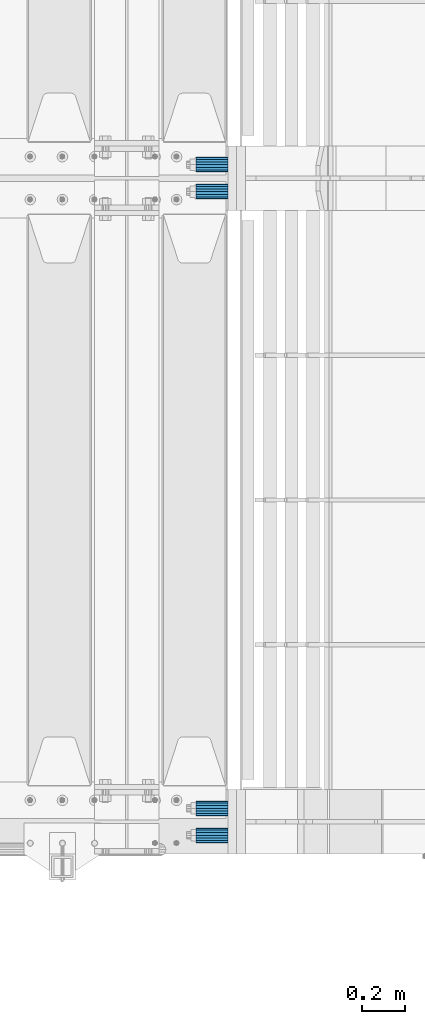
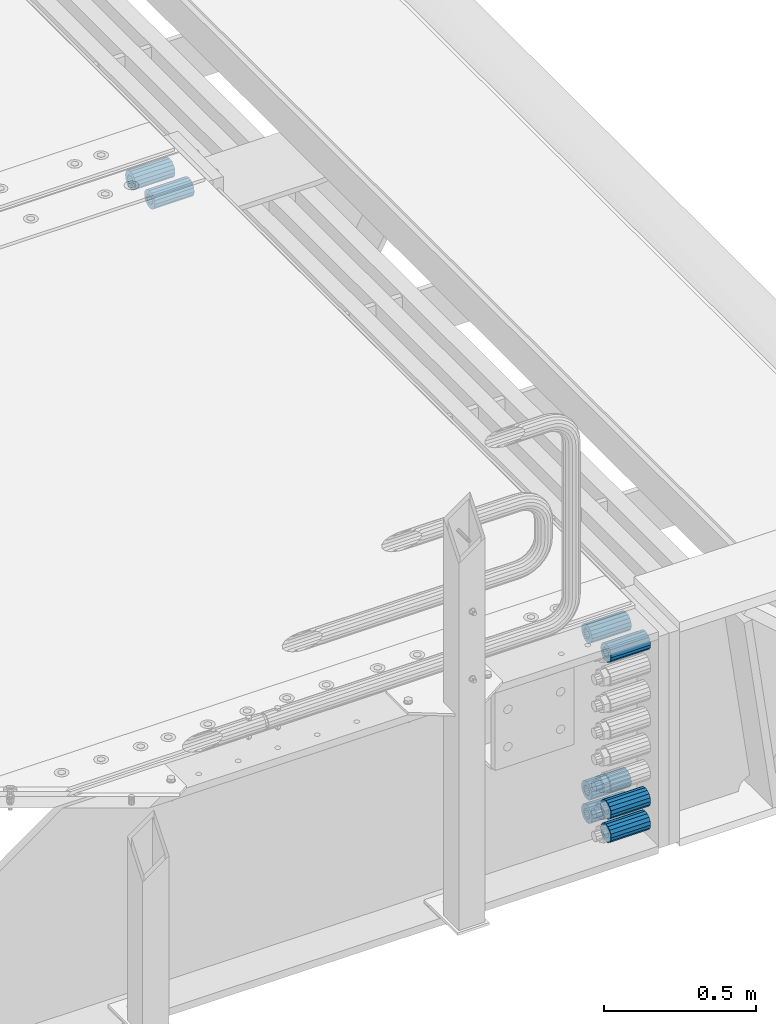
# One storey, part 132 of 208: 8 beams.
"""IFC2X3 building model written with IfcOpenShell, lengths in millimetres."""

from ifc_helpers import new_model, si_unit, frame, origin_with_axes, place, context, subcontext, project, spatial, faceted_brep, material, type_object, element, save


model = new_model("IFC2X3")

# Units and contexts
model_context = context("Model", 3, precision=1e-05, world=origin_with_axes())
body_context = subcontext(model_context, "Body", "Model", "MODEL_VIEW")
ifc_project = project(units=[si_unit("LENGTHUNIT", "METRE", prefix="MILLI"), si_unit("AREAUNIT", "SQUARE_METRE"), si_unit("VOLUMEUNIT", "CUBIC_METRE"), si_unit("MASSUNIT", "GRAM", prefix="KILO"), si_unit("TIMEUNIT", "SECOND"), si_unit("PLANEANGLEUNIT", "RADIAN"), si_unit("SOLIDANGLEUNIT", "STERADIAN"), si_unit("THERMODYNAMICTEMPERATUREUNIT", "DEGREE_CELSIUS"), si_unit("LUMINOUSINTENSITYUNIT", "LUMEN")], contexts=[model_context])

# Site, building, storey
site_placement = place(None, origin_with_axes())
site = spatial("IfcSite", under=ifc_project, at=site_placement, CompositionType="ELEMENT")
building_placement = place(site_placement, origin_with_axes())
building = spatial("IfcBuilding", under=site, at=building_placement, Name="Standard", CompositionType="ELEMENT")
storey_placement = place(building_placement, origin_with_axes())
storey = spatial("IfcBuildingStorey", under=building, at=storey_placement, Name="Undefined", CompositionType="ELEMENT", Elevation=0.0)

# Beams
ifc_material = material()
beam_type = type_object("IfcBeamType", PredefinedType="NOTDEFINED")
beam_1_placement = place(storey_placement, frame((-25783.0, 3063.0, -84.0000000000001), z_axis=(0.0, 0.0, 1.0), x_axis=(1.0, 0.0, 0.0)))
element("IfcBeam", 1, at=beam_1_placement, inside=storey, type_object=beam_type, material=ifc_material, context=body_context, shape_type="Brep", body=[
    faceted_brep([(-1.3120632047503e-07, -18.9999999995496, -6.26459950581193e-09), (0.0, -17.5537111177146, 7.27098521493672), (150.0, -17.5537111177146, 7.27098521493672), (150.0, -19.0, 0.0), (0.0, -13.4350288425444, 13.4350288425444), (150.0, -13.4350288425444, 13.4350288425444), (0.0, -7.2709852149369, 17.5537111177144), (150.0, -7.2709852149369, 17.5537111177144), (-6.33906438451959e-09, 4.50199877377599e-10, 18.9999999937354), (150.0, 0.0, 19.0), (0.0, 7.2709852149369, 17.5537111177144), (150.0, 7.2709852149369, 17.5537111177144), (0.0, 13.4350288425444, 13.4350288425444), (150.0, 13.4350288425444, 13.4350288425444), (0.0, 17.5537111177146, 7.2709852149367), (150.0, 17.5537111177146, 7.2709852149367), (1.33208345687308e-07, 19.0000000004507, -6.26459950581193e-09), (150.0, 19.0, 0.0), (0.0, 17.5537111177146, -7.2709852149367), (150.0, 17.5537111177146, -7.2709852149367), (0.0, 13.4350288425444, -13.4350288425444), (150.0, 13.4350288425444, -13.4350288425444), (0.0, 7.2709852149369, -17.5537111177144), (150.0, 7.2709852149369, -17.5537111177144), (8.34120328363497e-09, 4.50427251053043e-10, -19.0000000062646), (150.0, 0.0, -19.0), (0.0, -7.2709852149369, -17.5537111177144), (150.0, -7.2709852149369, -17.5537111177144), (0.0, -13.4350288425444, -13.4350288425444), (150.0, -13.4350288425444, -13.4350288425444), (0.0, -17.5537111177146, -7.2709852149367), (150.0, -17.5537111177146, -7.2709852149367), (0.0, -35.0, 0.0), (-3.63797880709171e-12, -32.335783637895, -13.3939201327782), (150.0, -32.335783637895, -13.3939201327782), (150.0, -35.0, 0.0), (0.0, -24.7487373415292, -24.7487373415291), (150.0, -24.7487373415293, -24.7487373415292), (0.0, -13.3939201327781, -32.335783637895), (150.0, -13.393920132778, -32.335783637895), (0.0, 0.0, -35.0), (150.0, 0.0, -35.0), (0.0, 13.3939201327782, -32.335783637895), (150.0, 13.393920132778, -32.335783637895), (0.0, 24.7487373415292, -24.7487373415291), (150.0, 24.7487373415293, -24.7487373415292), (-3.63797880709171e-12, 32.335783637895, -13.3939201327782), (150.0, 32.335783637895, -13.3939201327781), (0.0, 35.0, 0.0), (150.0, 35.0, 0.0), (0.0, 32.335783637895, 13.3939201327781), (150.0, 32.335783637895, 13.3939201327781), (0.0, 24.7487373415292, 24.748737341529), (150.0, 24.7487373415293, 24.7487373415292), (0.0, 13.3939201327781, 32.335783637895), (150.0, 13.393920132778, 32.335783637895), (-3.63797880709171e-12, 0.0, 35.0), (150.0, 0.0, 35.0), (0.0, -13.3939201327781, 32.335783637895), (150.0, -13.393920132778, 32.335783637895), (0.0, -24.7487373415292, 24.748737341529), (150.0, -24.7487373415293, 24.7487373415292), (0.0, -32.335783637895, 13.3939201327781), (150.0, -32.335783637895, 13.3939201327781)], [[[0, 1, 2, 3]], [[1, 4, 5, 2]], [[4, 6, 7, 5]], [[6, 8, 9, 7]], [[8, 10, 11, 9]], [[10, 12, 13, 11]], [[12, 14, 15, 13]], [[14, 16, 17, 15]], [[16, 18, 19, 17]], [[18, 20, 21, 19]], [[20, 22, 23, 21]], [[22, 24, 25, 23]], [[24, 26, 27, 25]], [[26, 28, 29, 27]], [[28, 30, 31, 29]], [[30, 0, 3, 31]], [[32, 33, 34, 35]], [[33, 36, 37, 34]], [[36, 38, 39, 37]], [[38, 40, 41, 39]], [[40, 42, 43, 41]], [[42, 44, 45, 43]], [[44, 46, 47, 45]], [[46, 48, 49, 47]], [[48, 50, 51, 49]], [[50, 52, 53, 51]], [[52, 54, 55, 53]], [[54, 56, 57, 55]], [[56, 58, 59, 57]], [[58, 60, 61, 59]], [[60, 62, 63, 61]], [[62, 32, 35, 63]], [[37, 39, 41, 43, 45, 47, 49, 51, 53, 55, 57, 59, 61, 63, 35, 34], [5, 7, 9, 11, 13, 15, 17, 19, 21, 23, 25, 27, 29, 31, 3, 2]], [[62, 60, 58, 56, 54, 52, 50, 48, 46, 44, 42, 40, 38, 36, 33, 32], [30, 28, 26, 24, 22, 20, 18, 16, 14, 12, 10, 8, 6, 4, 1, 0]]]),
])
beam_2_placement = place(storey_placement, frame((-25783.0, 2937.0, -84.0000000000001), z_axis=(0.0, 0.0, 1.0), x_axis=(1.0, 0.0, 0.0)))
element("IfcBeam", 2, at=beam_2_placement, inside=storey, type_object=beam_type, material=ifc_material, context=body_context, shape_type="Brep", body=[
    faceted_brep([(-1.3120632047503e-07, -18.9999999995496, -6.26459950581193e-09), (0.0, -17.5537111177146, 7.27098521493672), (150.0, -17.5537111177146, 7.27098521493672), (150.0, -19.0, 0.0), (0.0, -13.4350288425444, 13.4350288425444), (150.0, -13.4350288425444, 13.4350288425444), (0.0, -7.2709852149369, 17.5537111177144), (150.0, -7.2709852149369, 17.5537111177144), (-6.33906438451959e-09, 4.50199877377599e-10, 18.9999999937354), (150.0, 0.0, 19.0), (0.0, 7.2709852149369, 17.5537111177144), (150.0, 7.2709852149369, 17.5537111177144), (0.0, 13.4350288425444, 13.4350288425444), (150.0, 13.4350288425444, 13.4350288425444), (0.0, 17.5537111177146, 7.2709852149367), (150.0, 17.5537111177146, 7.2709852149367), (1.33208345687308e-07, 19.0000000004507, -6.26459950581193e-09), (150.0, 19.0, 0.0), (0.0, 17.5537111177146, -7.2709852149367), (150.0, 17.5537111177146, -7.2709852149367), (0.0, 13.4350288425444, -13.4350288425444), (150.0, 13.4350288425444, -13.4350288425444), (0.0, 7.2709852149369, -17.5537111177144), (150.0, 7.2709852149369, -17.5537111177144), (8.34120328363497e-09, 4.50427251053043e-10, -19.0000000062646), (150.0, 0.0, -19.0), (0.0, -7.2709852149369, -17.5537111177144), (150.0, -7.2709852149369, -17.5537111177144), (0.0, -13.4350288425444, -13.4350288425444), (150.0, -13.4350288425444, -13.4350288425444), (0.0, -17.5537111177146, -7.2709852149367), (150.0, -17.5537111177146, -7.2709852149367), (0.0, -35.0, 0.0), (-3.63797880709171e-12, -32.335783637895, -13.3939201327782), (150.0, -32.335783637895, -13.3939201327782), (150.0, -35.0, 0.0), (0.0, -24.7487373415292, -24.7487373415291), (150.0, -24.7487373415293, -24.7487373415292), (0.0, -13.3939201327781, -32.335783637895), (150.0, -13.393920132778, -32.335783637895), (0.0, 0.0, -35.0), (150.0, 0.0, -35.0), (0.0, 13.3939201327782, -32.335783637895), (150.0, 13.393920132778, -32.335783637895), (0.0, 24.7487373415292, -24.7487373415291), (150.0, 24.7487373415293, -24.7487373415292), (-3.63797880709171e-12, 32.335783637895, -13.3939201327782), (150.0, 32.335783637895, -13.3939201327781), (0.0, 35.0, 0.0), (150.0, 35.0, 0.0), (0.0, 32.335783637895, 13.3939201327781), (150.0, 32.335783637895, 13.3939201327781), (0.0, 24.7487373415292, 24.748737341529), (150.0, 24.7487373415293, 24.7487373415292), (0.0, 13.3939201327781, 32.335783637895), (150.0, 13.393920132778, 32.335783637895), (-3.63797880709171e-12, 0.0, 35.0), (150.0, 0.0, 35.0), (0.0, -13.3939201327781, 32.335783637895), (150.0, -13.393920132778, 32.335783637895), (0.0, -24.7487373415292, 24.748737341529), (150.0, -24.7487373415293, 24.7487373415292), (0.0, -32.335783637895, 13.3939201327781), (150.0, -32.335783637895, 13.3939201327781)], [[[0, 1, 2, 3]], [[1, 4, 5, 2]], [[4, 6, 7, 5]], [[6, 8, 9, 7]], [[8, 10, 11, 9]], [[10, 12, 13, 11]], [[12, 14, 15, 13]], [[14, 16, 17, 15]], [[16, 18, 19, 17]], [[18, 20, 21, 19]], [[20, 22, 23, 21]], [[22, 24, 25, 23]], [[24, 26, 27, 25]], [[26, 28, 29, 27]], [[28, 30, 31, 29]], [[30, 0, 3, 31]], [[32, 33, 34, 35]], [[33, 36, 37, 34]], [[36, 38, 39, 37]], [[38, 40, 41, 39]], [[40, 42, 43, 41]], [[42, 44, 45, 43]], [[44, 46, 47, 45]], [[46, 48, 49, 47]], [[48, 50, 51, 49]], [[50, 52, 53, 51]], [[52, 54, 55, 53]], [[54, 56, 57, 55]], [[56, 58, 59, 57]], [[58, 60, 61, 59]], [[60, 62, 63, 61]], [[62, 32, 35, 63]], [[37, 39, 41, 43, 45, 47, 49, 51, 53, 55, 57, 59, 61, 63, 35, 34], [5, 7, 9, 11, 13, 15, 17, 19, 21, 23, 25, 27, 29, 31, 3, 2]], [[62, 60, 58, 56, 54, 52, 50, 48, 46, 44, 42, 40, 38, 36, 33, 32], [30, 28, 26, 24, 22, 20, 18, 16, 14, 12, 10, 8, 6, 4, 1, 0]]]),
])
beam_3_placement = place(storey_placement, frame((-25783.0, -63.0, -84.0000000000001), z_axis=(0.0, 0.0, 1.0), x_axis=(1.0, 0.0, 0.0)))
element("IfcBeam", 3, at=beam_3_placement, inside=storey, type_object=beam_type, material=ifc_material, context=body_context, shape_type="Brep", body=[
    faceted_brep([(-1.3120632047503e-07, -18.9999999995496, -6.26459950581193e-09), (0.0, -17.5537111177146, 7.27098521493672), (150.0, -17.5537111177146, 7.27098521493672), (150.0, -19.0, 0.0), (0.0, -13.4350288425444, 13.4350288425444), (150.0, -13.4350288425444, 13.4350288425444), (0.0, -7.2709852149369, 17.5537111177144), (150.0, -7.2709852149369, 17.5537111177144), (-6.33906438451959e-09, 4.50199877377599e-10, 18.9999999937354), (150.0, 0.0, 19.0), (0.0, 7.2709852149369, 17.5537111177144), (150.0, 7.2709852149369, 17.5537111177144), (0.0, 13.4350288425444, 13.4350288425444), (150.0, 13.4350288425444, 13.4350288425444), (0.0, 17.5537111177146, 7.2709852149367), (150.0, 17.5537111177146, 7.2709852149367), (1.33208345687308e-07, 19.0000000004507, -6.26459950581193e-09), (150.0, 19.0, 0.0), (0.0, 17.5537111177146, -7.2709852149367), (150.0, 17.5537111177146, -7.2709852149367), (0.0, 13.4350288425444, -13.4350288425444), (150.0, 13.4350288425444, -13.4350288425444), (0.0, 7.2709852149369, -17.5537111177144), (150.0, 7.2709852149369, -17.5537111177144), (8.34120328363497e-09, 4.50427251053043e-10, -19.0000000062646), (150.0, 0.0, -19.0), (0.0, -7.2709852149369, -17.5537111177144), (150.0, -7.2709852149369, -17.5537111177144), (0.0, -13.4350288425444, -13.4350288425444), (150.0, -13.4350288425444, -13.4350288425444), (0.0, -17.5537111177146, -7.2709852149367), (150.0, -17.5537111177146, -7.2709852149367), (0.0, -35.0, 0.0), (-3.63797880709171e-12, -32.335783637895, -13.3939201327782), (150.0, -32.335783637895, -13.3939201327782), (150.0, -35.0, 0.0), (0.0, -24.7487373415292, -24.7487373415291), (150.0, -24.7487373415293, -24.7487373415292), (0.0, -13.3939201327781, -32.335783637895), (150.0, -13.393920132778, -32.335783637895), (0.0, 0.0, -35.0), (150.0, 0.0, -35.0), (0.0, 13.3939201327782, -32.335783637895), (150.0, 13.393920132778, -32.335783637895), (0.0, 24.7487373415292, -24.7487373415291), (150.0, 24.7487373415293, -24.7487373415292), (-3.63797880709171e-12, 32.335783637895, -13.3939201327782), (150.0, 32.335783637895, -13.3939201327781), (0.0, 35.0, 0.0), (150.0, 35.0, 0.0), (0.0, 32.335783637895, 13.3939201327781), (150.0, 32.335783637895, 13.3939201327781), (0.0, 24.7487373415292, 24.748737341529), (150.0, 24.7487373415293, 24.7487373415292), (0.0, 13.3939201327781, 32.335783637895), (150.0, 13.393920132778, 32.335783637895), (-3.63797880709171e-12, 0.0, 35.0), (150.0, 0.0, 35.0), (0.0, -13.3939201327781, 32.335783637895), (150.0, -13.393920132778, 32.335783637895), (0.0, -24.7487373415292, 24.748737341529), (150.0, -24.7487373415293, 24.7487373415292), (0.0, -32.335783637895, 13.3939201327781), (150.0, -32.335783637895, 13.3939201327781)], [[[0, 1, 2, 3]], [[1, 4, 5, 2]], [[4, 6, 7, 5]], [[6, 8, 9, 7]], [[8, 10, 11, 9]], [[10, 12, 13, 11]], [[12, 14, 15, 13]], [[14, 16, 17, 15]], [[16, 18, 19, 17]], [[18, 20, 21, 19]], [[20, 22, 23, 21]], [[22, 24, 25, 23]], [[24, 26, 27, 25]], [[26, 28, 29, 27]], [[28, 30, 31, 29]], [[30, 0, 3, 31]], [[32, 33, 34, 35]], [[33, 36, 37, 34]], [[36, 38, 39, 37]], [[38, 40, 41, 39]], [[40, 42, 43, 41]], [[42, 44, 45, 43]], [[44, 46, 47, 45]], [[46, 48, 49, 47]], [[48, 50, 51, 49]], [[50, 52, 53, 51]], [[52, 54, 55, 53]], [[54, 56, 57, 55]], [[56, 58, 59, 57]], [[58, 60, 61, 59]], [[60, 62, 63, 61]], [[62, 32, 35, 63]], [[37, 39, 41, 43, 45, 47, 49, 51, 53, 55, 57, 59, 61, 63, 35, 34], [5, 7, 9, 11, 13, 15, 17, 19, 21, 23, 25, 27, 29, 31, 3, 2]], [[62, 60, 58, 56, 54, 52, 50, 48, 46, 44, 42, 40, 38, 36, 33, 32], [30, 28, 26, 24, 22, 20, 18, 16, 14, 12, 10, 8, 6, 4, 1, 0]]]),
])
beam_4_placement = place(storey_placement, frame((-25783.0, 63.0, -713.0), z_axis=(0.0, 0.0, 1.0), x_axis=(1.0, 0.0, 0.0)))
element("IfcBeam", 4, at=beam_4_placement, inside=storey, type_object=beam_type, material=ifc_material, context=body_context, shape_type="Brep", body=[
    faceted_brep([(-1.3120632047503e-07, -18.9999999995496, -6.26459950581193e-09), (0.0, -17.5537111177146, 7.27098521493672), (150.0, -17.5537111177146, 7.27098521493672), (150.0, -19.0, 0.0), (0.0, -13.4350288425444, 13.4350288425444), (150.0, -13.4350288425444, 13.4350288425444), (0.0, -7.2709852149369, 17.5537111177144), (150.0, -7.2709852149369, 17.5537111177144), (-6.33906438451959e-09, 4.50199877377599e-10, 18.9999999937354), (150.0, 0.0, 19.0), (0.0, 7.2709852149369, 17.5537111177144), (150.0, 7.2709852149369, 17.5537111177144), (0.0, 13.4350288425444, 13.4350288425444), (150.0, 13.4350288425444, 13.4350288425444), (0.0, 17.5537111177146, 7.2709852149367), (150.0, 17.5537111177146, 7.2709852149367), (1.33208345687308e-07, 19.0000000004507, -6.26459950581193e-09), (150.0, 19.0, 0.0), (0.0, 17.5537111177146, -7.2709852149367), (150.0, 17.5537111177146, -7.2709852149367), (0.0, 13.4350288425444, -13.4350288425444), (150.0, 13.4350288425444, -13.4350288425444), (0.0, 7.2709852149369, -17.5537111177144), (150.0, 7.2709852149369, -17.5537111177144), (8.34120328363497e-09, 4.50427251053043e-10, -19.0000000062646), (150.0, 0.0, -19.0), (0.0, -7.2709852149369, -17.5537111177144), (150.0, -7.2709852149369, -17.5537111177144), (0.0, -13.4350288425444, -13.4350288425444), (150.0, -13.4350288425444, -13.4350288425444), (0.0, -17.5537111177146, -7.2709852149367), (150.0, -17.5537111177146, -7.2709852149367), (0.0, -35.0, 0.0), (-3.63797880709171e-12, -32.335783637895, -13.3939201327782), (150.0, -32.335783637895, -13.3939201327782), (150.0, -35.0, 0.0), (0.0, -24.7487373415292, -24.7487373415291), (150.0, -24.7487373415293, -24.7487373415292), (0.0, -13.3939201327781, -32.335783637895), (150.0, -13.393920132778, -32.335783637895), (0.0, 0.0, -35.0), (150.0, 0.0, -35.0), (0.0, 13.3939201327782, -32.335783637895), (150.0, 13.393920132778, -32.335783637895), (0.0, 24.7487373415292, -24.7487373415291), (150.0, 24.7487373415293, -24.7487373415292), (-3.63797880709171e-12, 32.335783637895, -13.3939201327782), (150.0, 32.335783637895, -13.3939201327781), (0.0, 35.0, 0.0), (150.0, 35.0, 0.0), (0.0, 32.335783637895, 13.3939201327781), (150.0, 32.335783637895, 13.3939201327781), (0.0, 24.7487373415292, 24.748737341529), (150.0, 24.7487373415293, 24.7487373415292), (0.0, 13.3939201327781, 32.335783637895), (150.0, 13.393920132778, 32.335783637895), (-3.63797880709171e-12, 0.0, 35.0), (150.0, 0.0, 35.0), (0.0, -13.3939201327781, 32.335783637895), (150.0, -13.393920132778, 32.335783637895), (0.0, -24.7487373415292, 24.748737341529), (150.0, -24.7487373415293, 24.7487373415292), (0.0, -32.335783637895, 13.3939201327781), (150.0, -32.335783637895, 13.3939201327781)], [[[0, 1, 2, 3]], [[1, 4, 5, 2]], [[4, 6, 7, 5]], [[6, 8, 9, 7]], [[8, 10, 11, 9]], [[10, 12, 13, 11]], [[12, 14, 15, 13]], [[14, 16, 17, 15]], [[16, 18, 19, 17]], [[18, 20, 21, 19]], [[20, 22, 23, 21]], [[22, 24, 25, 23]], [[24, 26, 27, 25]], [[26, 28, 29, 27]], [[28, 30, 31, 29]], [[30, 0, 3, 31]], [[32, 33, 34, 35]], [[33, 36, 37, 34]], [[36, 38, 39, 37]], [[38, 40, 41, 39]], [[40, 42, 43, 41]], [[42, 44, 45, 43]], [[44, 46, 47, 45]], [[46, 48, 49, 47]], [[48, 50, 51, 49]], [[50, 52, 53, 51]], [[52, 54, 55, 53]], [[54, 56, 57, 55]], [[56, 58, 59, 57]], [[58, 60, 61, 59]], [[60, 62, 63, 61]], [[62, 32, 35, 63]], [[37, 39, 41, 43, 45, 47, 49, 51, 53, 55, 57, 59, 61, 63, 35, 34], [5, 7, 9, 11, 13, 15, 17, 19, 21, 23, 25, 27, 29, 31, 3, 2]], [[62, 60, 58, 56, 54, 52, 50, 48, 46, 44, 42, 40, 38, 36, 33, 32], [30, 28, 26, 24, 22, 20, 18, 16, 14, 12, 10, 8, 6, 4, 1, 0]]]),
])
beam_5_placement = place(storey_placement, frame((-25783.0, 63.0, -84.0000000000001), z_axis=(0.0, 0.0, 1.0), x_axis=(1.0, 0.0, 0.0)))
element("IfcBeam", 5, at=beam_5_placement, inside=storey, type_object=beam_type, material=ifc_material, context=body_context, shape_type="Brep", body=[
    faceted_brep([(-1.3120632047503e-07, -18.9999999995496, -6.26459950581193e-09), (0.0, -17.5537111177146, 7.27098521493672), (150.0, -17.5537111177146, 7.27098521493672), (150.0, -19.0, 0.0), (0.0, -13.4350288425444, 13.4350288425444), (150.0, -13.4350288425444, 13.4350288425444), (0.0, -7.2709852149369, 17.5537111177144), (150.0, -7.2709852149369, 17.5537111177144), (-6.33906438451959e-09, 4.50199877377599e-10, 18.9999999937354), (150.0, 0.0, 19.0), (0.0, 7.2709852149369, 17.5537111177144), (150.0, 7.2709852149369, 17.5537111177144), (0.0, 13.4350288425444, 13.4350288425444), (150.0, 13.4350288425444, 13.4350288425444), (0.0, 17.5537111177146, 7.2709852149367), (150.0, 17.5537111177146, 7.2709852149367), (1.33208345687308e-07, 19.0000000004507, -6.26459950581193e-09), (150.0, 19.0, 0.0), (0.0, 17.5537111177146, -7.2709852149367), (150.0, 17.5537111177146, -7.2709852149367), (0.0, 13.4350288425444, -13.4350288425444), (150.0, 13.4350288425444, -13.4350288425444), (0.0, 7.2709852149369, -17.5537111177144), (150.0, 7.2709852149369, -17.5537111177144), (8.34120328363497e-09, 4.50427251053043e-10, -19.0000000062646), (150.0, 0.0, -19.0), (0.0, -7.2709852149369, -17.5537111177144), (150.0, -7.2709852149369, -17.5537111177144), (0.0, -13.4350288425444, -13.4350288425444), (150.0, -13.4350288425444, -13.4350288425444), (0.0, -17.5537111177146, -7.2709852149367), (150.0, -17.5537111177146, -7.2709852149367), (0.0, -35.0, 0.0), (-3.63797880709171e-12, -32.335783637895, -13.3939201327782), (150.0, -32.335783637895, -13.3939201327782), (150.0, -35.0, 0.0), (0.0, -24.7487373415292, -24.7487373415291), (150.0, -24.7487373415293, -24.7487373415292), (0.0, -13.3939201327781, -32.335783637895), (150.0, -13.393920132778, -32.335783637895), (0.0, 0.0, -35.0), (150.0, 0.0, -35.0), (0.0, 13.3939201327782, -32.335783637895), (150.0, 13.393920132778, -32.335783637895), (0.0, 24.7487373415292, -24.7487373415291), (150.0, 24.7487373415293, -24.7487373415292), (-3.63797880709171e-12, 32.335783637895, -13.3939201327782), (150.0, 32.335783637895, -13.3939201327781), (0.0, 35.0, 0.0), (150.0, 35.0, 0.0), (0.0, 32.335783637895, 13.3939201327781), (150.0, 32.335783637895, 13.3939201327781), (0.0, 24.7487373415292, 24.748737341529), (150.0, 24.7487373415293, 24.7487373415292), (0.0, 13.3939201327781, 32.335783637895), (150.0, 13.393920132778, 32.335783637895), (-3.63797880709171e-12, 0.0, 35.0), (150.0, 0.0, 35.0), (0.0, -13.3939201327781, 32.335783637895), (150.0, -13.393920132778, 32.335783637895), (0.0, -24.7487373415292, 24.748737341529), (150.0, -24.7487373415293, 24.7487373415292), (0.0, -32.335783637895, 13.3939201327781), (150.0, -32.335783637895, 13.3939201327781)], [[[0, 1, 2, 3]], [[1, 4, 5, 2]], [[4, 6, 7, 5]], [[6, 8, 9, 7]], [[8, 10, 11, 9]], [[10, 12, 13, 11]], [[12, 14, 15, 13]], [[14, 16, 17, 15]], [[16, 18, 19, 17]], [[18, 20, 21, 19]], [[20, 22, 23, 21]], [[22, 24, 25, 23]], [[24, 26, 27, 25]], [[26, 28, 29, 27]], [[28, 30, 31, 29]], [[30, 0, 3, 31]], [[32, 33, 34, 35]], [[33, 36, 37, 34]], [[36, 38, 39, 37]], [[38, 40, 41, 39]], [[40, 42, 43, 41]], [[42, 44, 45, 43]], [[44, 46, 47, 45]], [[46, 48, 49, 47]], [[48, 50, 51, 49]], [[50, 52, 53, 51]], [[52, 54, 55, 53]], [[54, 56, 57, 55]], [[56, 58, 59, 57]], [[58, 60, 61, 59]], [[60, 62, 63, 61]], [[62, 32, 35, 63]], [[37, 39, 41, 43, 45, 47, 49, 51, 53, 55, 57, 59, 61, 63, 35, 34], [5, 7, 9, 11, 13, 15, 17, 19, 21, 23, 25, 27, 29, 31, 3, 2]], [[62, 60, 58, 56, 54, 52, 50, 48, 46, 44, 42, 40, 38, 36, 33, 32], [30, 28, 26, 24, 22, 20, 18, 16, 14, 12, 10, 8, 6, 4, 1, 0]]]),
])
beam_6_placement = place(storey_placement, frame((-25783.0, -63.0, -713.0), z_axis=(0.0, 0.0, 1.0), x_axis=(1.0, 0.0, 0.0)))
element("IfcBeam", 6, at=beam_6_placement, inside=storey, type_object=beam_type, material=ifc_material, context=body_context, shape_type="Brep", body=[
    faceted_brep([(-1.3120632047503e-07, -18.9999999995496, -6.26459950581193e-09), (0.0, -17.5537111177146, 7.27098521493672), (150.0, -17.5537111177146, 7.27098521493672), (150.0, -19.0, 0.0), (0.0, -13.4350288425444, 13.4350288425444), (150.0, -13.4350288425444, 13.4350288425444), (0.0, -7.2709852149369, 17.5537111177144), (150.0, -7.2709852149369, 17.5537111177144), (-6.33906438451959e-09, 4.50199877377599e-10, 18.9999999937354), (150.0, 0.0, 19.0), (0.0, 7.2709852149369, 17.5537111177144), (150.0, 7.2709852149369, 17.5537111177144), (0.0, 13.4350288425444, 13.4350288425444), (150.0, 13.4350288425444, 13.4350288425444), (0.0, 17.5537111177146, 7.2709852149367), (150.0, 17.5537111177146, 7.2709852149367), (1.33208345687308e-07, 19.0000000004507, -6.26459950581193e-09), (150.0, 19.0, 0.0), (0.0, 17.5537111177146, -7.2709852149367), (150.0, 17.5537111177146, -7.2709852149367), (0.0, 13.4350288425444, -13.4350288425444), (150.0, 13.4350288425444, -13.4350288425444), (0.0, 7.2709852149369, -17.5537111177144), (150.0, 7.2709852149369, -17.5537111177144), (8.34120328363497e-09, 4.50427251053043e-10, -19.0000000062646), (150.0, 0.0, -19.0), (0.0, -7.2709852149369, -17.5537111177144), (150.0, -7.2709852149369, -17.5537111177144), (0.0, -13.4350288425444, -13.4350288425444), (150.0, -13.4350288425444, -13.4350288425444), (0.0, -17.5537111177146, -7.2709852149367), (150.0, -17.5537111177146, -7.2709852149367), (0.0, -35.0, 0.0), (-3.63797880709171e-12, -32.335783637895, -13.3939201327782), (150.0, -32.335783637895, -13.3939201327782), (150.0, -35.0, 0.0), (0.0, -24.7487373415292, -24.7487373415291), (150.0, -24.7487373415293, -24.7487373415292), (0.0, -13.3939201327781, -32.335783637895), (150.0, -13.393920132778, -32.335783637895), (0.0, 0.0, -35.0), (150.0, 0.0, -35.0), (0.0, 13.3939201327782, -32.335783637895), (150.0, 13.393920132778, -32.335783637895), (0.0, 24.7487373415292, -24.7487373415291), (150.0, 24.7487373415293, -24.7487373415292), (-3.63797880709171e-12, 32.335783637895, -13.3939201327782), (150.0, 32.335783637895, -13.3939201327781), (0.0, 35.0, 0.0), (150.0, 35.0, 0.0), (0.0, 32.335783637895, 13.3939201327781), (150.0, 32.335783637895, 13.3939201327781), (0.0, 24.7487373415292, 24.748737341529), (150.0, 24.7487373415293, 24.7487373415292), (0.0, 13.3939201327781, 32.335783637895), (150.0, 13.393920132778, 32.335783637895), (-3.63797880709171e-12, 0.0, 35.0), (150.0, 0.0, 35.0), (0.0, -13.3939201327781, 32.335783637895), (150.0, -13.393920132778, 32.335783637895), (0.0, -24.7487373415292, 24.748737341529), (150.0, -24.7487373415293, 24.7487373415292), (0.0, -32.335783637895, 13.3939201327781), (150.0, -32.335783637895, 13.3939201327781)], [[[0, 1, 2, 3]], [[1, 4, 5, 2]], [[4, 6, 7, 5]], [[6, 8, 9, 7]], [[8, 10, 11, 9]], [[10, 12, 13, 11]], [[12, 14, 15, 13]], [[14, 16, 17, 15]], [[16, 18, 19, 17]], [[18, 20, 21, 19]], [[20, 22, 23, 21]], [[22, 24, 25, 23]], [[24, 26, 27, 25]], [[26, 28, 29, 27]], [[28, 30, 31, 29]], [[30, 0, 3, 31]], [[32, 33, 34, 35]], [[33, 36, 37, 34]], [[36, 38, 39, 37]], [[38, 40, 41, 39]], [[40, 42, 43, 41]], [[42, 44, 45, 43]], [[44, 46, 47, 45]], [[46, 48, 49, 47]], [[48, 50, 51, 49]], [[50, 52, 53, 51]], [[52, 54, 55, 53]], [[54, 56, 57, 55]], [[56, 58, 59, 57]], [[58, 60, 61, 59]], [[60, 62, 63, 61]], [[62, 32, 35, 63]], [[37, 39, 41, 43, 45, 47, 49, 51, 53, 55, 57, 59, 61, 63, 35, 34], [5, 7, 9, 11, 13, 15, 17, 19, 21, 23, 25, 27, 29, 31, 3, 2]], [[62, 60, 58, 56, 54, 52, 50, 48, 46, 44, 42, 40, 38, 36, 33, 32], [30, 28, 26, 24, 22, 20, 18, 16, 14, 12, 10, 8, 6, 4, 1, 0]]]),
])
beam_7_placement = place(storey_placement, frame((-25783.0, 63.0, -807.0), z_axis=(0.0, 0.0, 1.0), x_axis=(1.0, 0.0, 0.0)))
element("IfcBeam", 7, at=beam_7_placement, inside=storey, type_object=beam_type, material=ifc_material, context=body_context, shape_type="Brep", body=[
    faceted_brep([(-1.3120632047503e-07, -18.9999999995496, -6.26459950581193e-09), (0.0, -17.5537111177146, 7.27098521493672), (150.0, -17.5537111177146, 7.27098521493672), (150.0, -19.0, 0.0), (0.0, -13.4350288425444, 13.4350288425444), (150.0, -13.4350288425444, 13.4350288425444), (0.0, -7.2709852149369, 17.5537111177144), (150.0, -7.2709852149369, 17.5537111177144), (-6.33906438451959e-09, 4.50199877377599e-10, 18.9999999937354), (150.0, 0.0, 19.0), (0.0, 7.2709852149369, 17.5537111177144), (150.0, 7.2709852149369, 17.5537111177144), (0.0, 13.4350288425444, 13.4350288425444), (150.0, 13.4350288425444, 13.4350288425444), (0.0, 17.5537111177146, 7.2709852149367), (150.0, 17.5537111177146, 7.2709852149367), (1.33208345687308e-07, 19.0000000004507, -6.26459950581193e-09), (150.0, 19.0, 0.0), (0.0, 17.5537111177146, -7.2709852149367), (150.0, 17.5537111177146, -7.2709852149367), (0.0, 13.4350288425444, -13.4350288425444), (150.0, 13.4350288425444, -13.4350288425444), (0.0, 7.2709852149369, -17.5537111177144), (150.0, 7.2709852149369, -17.5537111177144), (8.34120328363497e-09, 4.50427251053043e-10, -19.0000000062646), (150.0, 0.0, -19.0), (0.0, -7.2709852149369, -17.5537111177144), (150.0, -7.2709852149369, -17.5537111177144), (0.0, -13.4350288425444, -13.4350288425444), (150.0, -13.4350288425444, -13.4350288425444), (0.0, -17.5537111177146, -7.2709852149367), (150.0, -17.5537111177146, -7.2709852149367), (0.0, -35.0, 0.0), (-3.63797880709171e-12, -32.335783637895, -13.3939201327782), (150.0, -32.335783637895, -13.3939201327782), (150.0, -35.0, 0.0), (0.0, -24.7487373415292, -24.7487373415291), (150.0, -24.7487373415293, -24.7487373415292), (0.0, -13.3939201327781, -32.335783637895), (150.0, -13.393920132778, -32.335783637895), (0.0, 0.0, -35.0), (150.0, 0.0, -35.0), (0.0, 13.3939201327782, -32.335783637895), (150.0, 13.393920132778, -32.335783637895), (0.0, 24.7487373415292, -24.7487373415291), (150.0, 24.7487373415293, -24.7487373415292), (-3.63797880709171e-12, 32.335783637895, -13.3939201327782), (150.0, 32.335783637895, -13.3939201327781), (0.0, 35.0, 0.0), (150.0, 35.0, 0.0), (0.0, 32.335783637895, 13.3939201327781), (150.0, 32.335783637895, 13.3939201327781), (0.0, 24.7487373415292, 24.748737341529), (150.0, 24.7487373415293, 24.7487373415292), (0.0, 13.3939201327781, 32.335783637895), (150.0, 13.393920132778, 32.335783637895), (-3.63797880709171e-12, 0.0, 35.0), (150.0, 0.0, 35.0), (0.0, -13.3939201327781, 32.335783637895), (150.0, -13.393920132778, 32.335783637895), (0.0, -24.7487373415292, 24.748737341529), (150.0, -24.7487373415293, 24.7487373415292), (0.0, -32.335783637895, 13.3939201327781), (150.0, -32.335783637895, 13.3939201327781)], [[[0, 1, 2, 3]], [[1, 4, 5, 2]], [[4, 6, 7, 5]], [[6, 8, 9, 7]], [[8, 10, 11, 9]], [[10, 12, 13, 11]], [[12, 14, 15, 13]], [[14, 16, 17, 15]], [[16, 18, 19, 17]], [[18, 20, 21, 19]], [[20, 22, 23, 21]], [[22, 24, 25, 23]], [[24, 26, 27, 25]], [[26, 28, 29, 27]], [[28, 30, 31, 29]], [[30, 0, 3, 31]], [[32, 33, 34, 35]], [[33, 36, 37, 34]], [[36, 38, 39, 37]], [[38, 40, 41, 39]], [[40, 42, 43, 41]], [[42, 44, 45, 43]], [[44, 46, 47, 45]], [[46, 48, 49, 47]], [[48, 50, 51, 49]], [[50, 52, 53, 51]], [[52, 54, 55, 53]], [[54, 56, 57, 55]], [[56, 58, 59, 57]], [[58, 60, 61, 59]], [[60, 62, 63, 61]], [[62, 32, 35, 63]], [[37, 39, 41, 43, 45, 47, 49, 51, 53, 55, 57, 59, 61, 63, 35, 34], [5, 7, 9, 11, 13, 15, 17, 19, 21, 23, 25, 27, 29, 31, 3, 2]], [[62, 60, 58, 56, 54, 52, 50, 48, 46, 44, 42, 40, 38, 36, 33, 32], [30, 28, 26, 24, 22, 20, 18, 16, 14, 12, 10, 8, 6, 4, 1, 0]]]),
])
beam_8_placement = place(storey_placement, frame((-25783.0, -63.0, -807.0), z_axis=(0.0, 0.0, 1.0), x_axis=(1.0, 0.0, 0.0)))
element("IfcBeam", 8, at=beam_8_placement, inside=storey, type_object=beam_type, material=ifc_material, context=body_context, shape_type="Brep", body=[
    faceted_brep([(-1.3120632047503e-07, -18.9999999995496, -6.26459950581193e-09), (0.0, -17.5537111177146, 7.27098521493672), (150.0, -17.5537111177146, 7.27098521493672), (150.0, -19.0, 0.0), (0.0, -13.4350288425444, 13.4350288425444), (150.0, -13.4350288425444, 13.4350288425444), (0.0, -7.2709852149369, 17.5537111177144), (150.0, -7.2709852149369, 17.5537111177144), (-6.33906438451959e-09, 4.50199877377599e-10, 18.9999999937354), (150.0, 0.0, 19.0), (0.0, 7.2709852149369, 17.5537111177144), (150.0, 7.2709852149369, 17.5537111177144), (0.0, 13.4350288425444, 13.4350288425444), (150.0, 13.4350288425444, 13.4350288425444), (0.0, 17.5537111177146, 7.2709852149367), (150.0, 17.5537111177146, 7.2709852149367), (1.33208345687308e-07, 19.0000000004507, -6.26459950581193e-09), (150.0, 19.0, 0.0), (0.0, 17.5537111177146, -7.2709852149367), (150.0, 17.5537111177146, -7.2709852149367), (0.0, 13.4350288425444, -13.4350288425444), (150.0, 13.4350288425444, -13.4350288425444), (0.0, 7.2709852149369, -17.5537111177144), (150.0, 7.2709852149369, -17.5537111177144), (8.34120328363497e-09, 4.50427251053043e-10, -19.0000000062646), (150.0, 0.0, -19.0), (0.0, -7.2709852149369, -17.5537111177144), (150.0, -7.2709852149369, -17.5537111177144), (0.0, -13.4350288425444, -13.4350288425444), (150.0, -13.4350288425444, -13.4350288425444), (0.0, -17.5537111177146, -7.2709852149367), (150.0, -17.5537111177146, -7.2709852149367), (0.0, -35.0, 0.0), (-3.63797880709171e-12, -32.335783637895, -13.3939201327782), (150.0, -32.335783637895, -13.3939201327782), (150.0, -35.0, 0.0), (0.0, -24.7487373415292, -24.7487373415291), (150.0, -24.7487373415293, -24.7487373415292), (0.0, -13.3939201327781, -32.335783637895), (150.0, -13.393920132778, -32.335783637895), (0.0, 0.0, -35.0), (150.0, 0.0, -35.0), (0.0, 13.3939201327782, -32.335783637895), (150.0, 13.393920132778, -32.335783637895), (0.0, 24.7487373415292, -24.7487373415291), (150.0, 24.7487373415293, -24.7487373415292), (-3.63797880709171e-12, 32.335783637895, -13.3939201327782), (150.0, 32.335783637895, -13.3939201327781), (0.0, 35.0, 0.0), (150.0, 35.0, 0.0), (0.0, 32.335783637895, 13.3939201327781), (150.0, 32.335783637895, 13.3939201327781), (0.0, 24.7487373415292, 24.748737341529), (150.0, 24.7487373415293, 24.7487373415292), (0.0, 13.3939201327781, 32.335783637895), (150.0, 13.393920132778, 32.335783637895), (-3.63797880709171e-12, 0.0, 35.0), (150.0, 0.0, 35.0), (0.0, -13.3939201327781, 32.335783637895), (150.0, -13.393920132778, 32.335783637895), (0.0, -24.7487373415292, 24.748737341529), (150.0, -24.7487373415293, 24.7487373415292), (0.0, -32.335783637895, 13.3939201327781), (150.0, -32.335783637895, 13.3939201327781)], [[[0, 1, 2, 3]], [[1, 4, 5, 2]], [[4, 6, 7, 5]], [[6, 8, 9, 7]], [[8, 10, 11, 9]], [[10, 12, 13, 11]], [[12, 14, 15, 13]], [[14, 16, 17, 15]], [[16, 18, 19, 17]], [[18, 20, 21, 19]], [[20, 22, 23, 21]], [[22, 24, 25, 23]], [[24, 26, 27, 25]], [[26, 28, 29, 27]], [[28, 30, 31, 29]], [[30, 0, 3, 31]], [[32, 33, 34, 35]], [[33, 36, 37, 34]], [[36, 38, 39, 37]], [[38, 40, 41, 39]], [[40, 42, 43, 41]], [[42, 44, 45, 43]], [[44, 46, 47, 45]], [[46, 48, 49, 47]], [[48, 50, 51, 49]], [[50, 52, 53, 51]], [[52, 54, 55, 53]], [[54, 56, 57, 55]], [[56, 58, 59, 57]], [[58, 60, 61, 59]], [[60, 62, 63, 61]], [[62, 32, 35, 63]], [[37, 39, 41, 43, 45, 47, 49, 51, 53, 55, 57, 59, 61, 63, 35, 34], [5, 7, 9, 11, 13, 15, 17, 19, 21, 23, 25, 27, 29, 31, 3, 2]], [[62, 60, 58, 56, 54, 52, 50, 48, 46, 44, 42, 40, 38, 36, 33, 32], [30, 28, 26, 24, 22, 20, 18, 16, 14, 12, 10, 8, 6, 4, 1, 0]]]),
])

save(model, "model.ifc")
